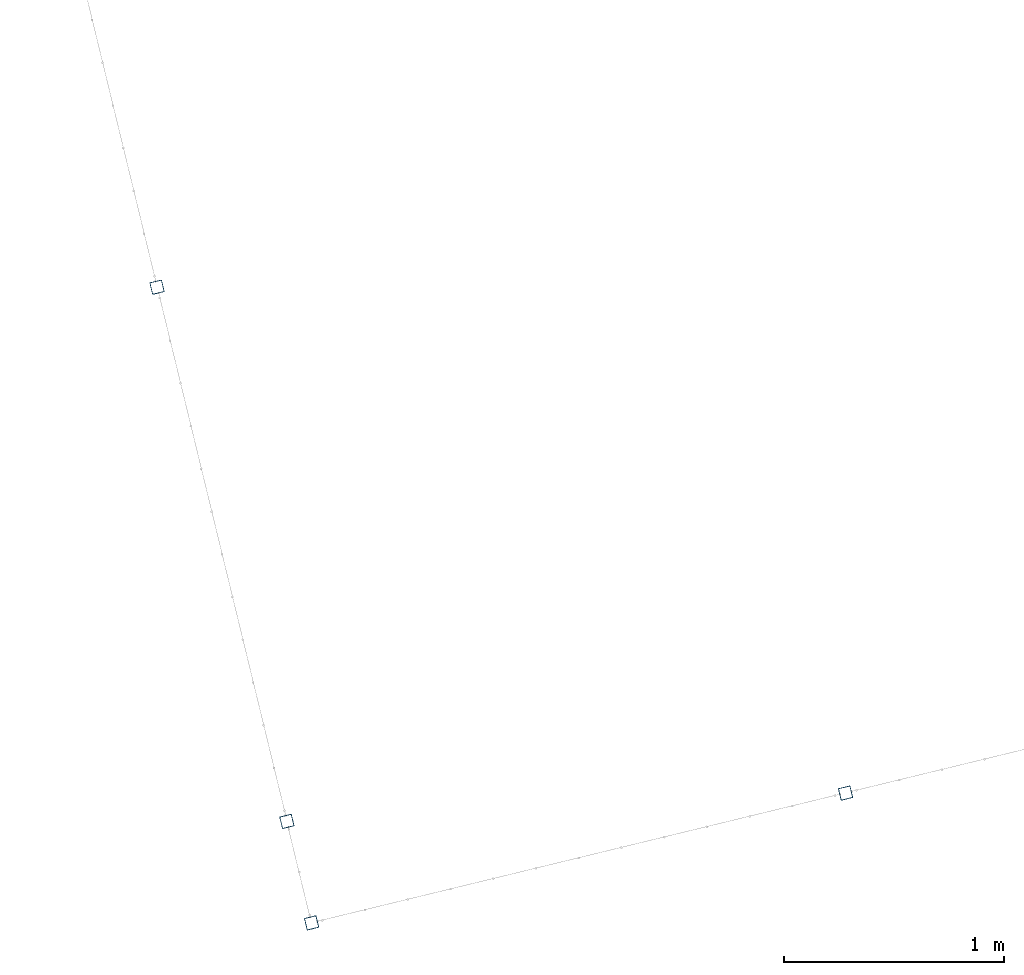
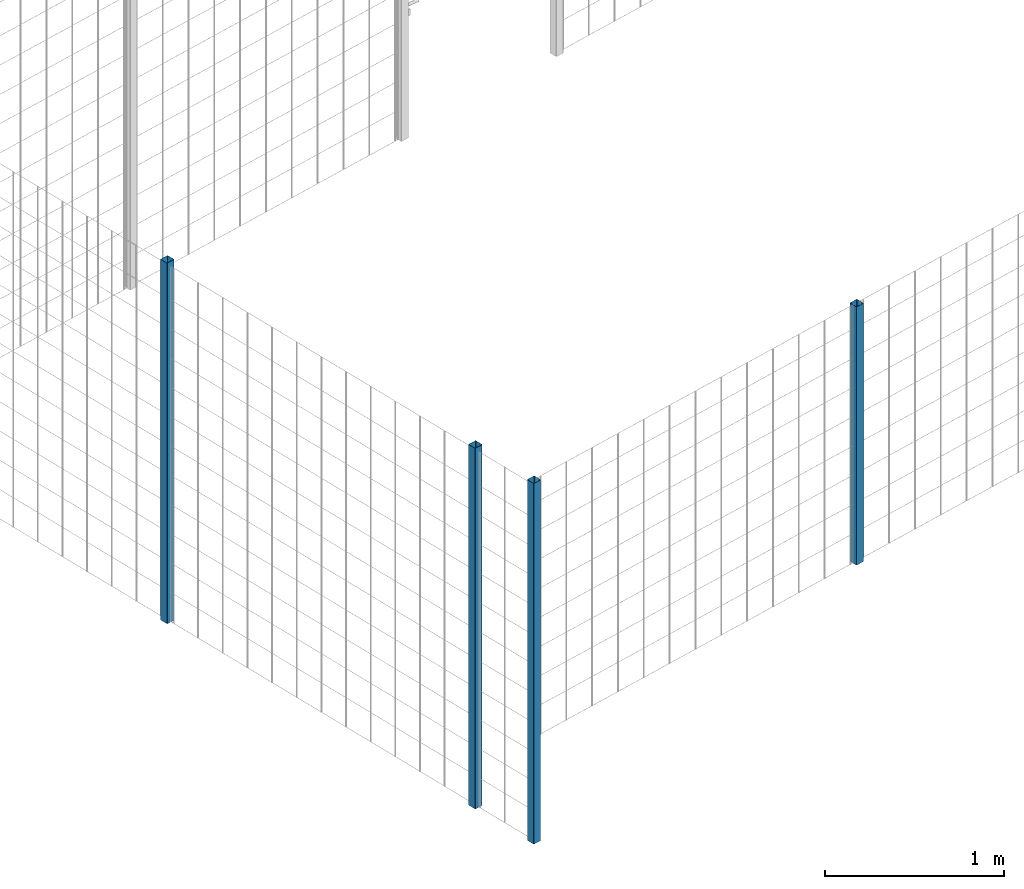
# One storey, part 1 of 10: 4 beams.
"""IFC2X3 building model written with IfcOpenShell, lengths in millimetres."""

from ifc_helpers import new_model, entity, si_unit, converted_unit, derived_unit, direction, frame, frame_2d, origin, place, context, subcontext, project, spatial, polyline, circle_curve, parameter, trimmed, segment, composite_curve, outline, extrude, material, type_object, element, save


model = new_model("IFC2X3")

# Units and contexts
model_context = context("Model", 3, precision=0.01, world=origin(), true_north=direction((6.12303176911189e-17, 1.0)))
body_context = subcontext(model_context, "Body", "Model", "MODEL_VIEW")
ifc_project = project(units=[si_unit("LENGTHUNIT", "METRE", prefix="MILLI"), si_unit("AREAUNIT", "SQUARE_METRE"), si_unit("VOLUMEUNIT", "CUBIC_METRE"), converted_unit("PLANEANGLEUNIT", "DEGREE", entity("IfcRatioMeasure", 0.0174532925199433), si_unit("PLANEANGLEUNIT", "RADIAN"), dimensions=[0, 0, 0, 0, 0, 0, 0]), si_unit("MASSUNIT", "GRAM", prefix="KILO"), derived_unit("MASSDENSITYUNIT", [(si_unit("MASSUNIT", "GRAM", prefix="KILO"), 1), (si_unit("LENGTHUNIT", "METRE"), -3)]), derived_unit("MOMENTOFINERTIAUNIT", [(si_unit("LENGTHUNIT", "METRE"), 4)]), si_unit("TIMEUNIT", "SECOND"), si_unit("FREQUENCYUNIT", "HERTZ"), si_unit("THERMODYNAMICTEMPERATUREUNIT", "DEGREE_CELSIUS"), derived_unit("THERMALTRANSMITTANCEUNIT", [(si_unit("MASSUNIT", "GRAM", prefix="KILO"), 1), (si_unit("THERMODYNAMICTEMPERATUREUNIT", "KELVIN"), -1), (si_unit("TIMEUNIT", "SECOND"), -3)]), derived_unit("VOLUMETRICFLOWRATEUNIT", [(si_unit("LENGTHUNIT", "METRE"), 3), (si_unit("TIMEUNIT", "SECOND"), -1)]), derived_unit("MASSFLOWRATEUNIT", [(si_unit("MASSUNIT", "GRAM", prefix="KILO"), 1), (si_unit("TIMEUNIT", "SECOND"), -1)]), derived_unit("ROTATIONALFREQUENCYUNIT", [(si_unit("TIMEUNIT", "SECOND"), -1)]), si_unit("ELECTRICCURRENTUNIT", "AMPERE"), si_unit("ELECTRICVOLTAGEUNIT", "VOLT"), si_unit("POWERUNIT", "WATT"), si_unit("FORCEUNIT", "NEWTON", prefix="KILO"), si_unit("ILLUMINANCEUNIT", "LUX"), si_unit("LUMINOUSFLUXUNIT", "LUMEN"), si_unit("LUMINOUSINTENSITYUNIT", "CANDELA"), derived_unit("USERDEFINED", [(si_unit("MASSUNIT", "GRAM", prefix="KILO"), -1), (si_unit("LENGTHUNIT", "METRE"), -2), (si_unit("TIMEUNIT", "SECOND"), 3), (si_unit("LUMINOUSFLUXUNIT", "LUMEN"), 1)]), derived_unit("LINEARVELOCITYUNIT", [(si_unit("LENGTHUNIT", "METRE"), 1), (si_unit("TIMEUNIT", "SECOND"), -1)]), si_unit("PRESSUREUNIT", "PASCAL"), derived_unit("USERDEFINED", [(si_unit("LENGTHUNIT", "METRE"), -2), (si_unit("MASSUNIT", "GRAM", prefix="KILO"), 1), (si_unit("TIMEUNIT", "SECOND"), -2)]), derived_unit("LINEARFORCEUNIT", [(si_unit("MASSUNIT", "GRAM", prefix="KILO"), 1), (si_unit("LENGTHUNIT", "METRE"), 1), (si_unit("TIMEUNIT", "SECOND"), -2), (si_unit("LENGTHUNIT", "METRE"), -1)]), derived_unit("PLANARFORCEUNIT", [(si_unit("MASSUNIT", "GRAM", prefix="KILO"), 1), (si_unit("LENGTHUNIT", "METRE"), 1), (si_unit("TIMEUNIT", "SECOND"), -2), (si_unit("LENGTHUNIT", "METRE"), -2)])], contexts=[model_context])

# Site, building, storey
site_placement = place(None, frame((19171.746869958, -72498.5768491146, 0.0), z_axis=(0.0, 0.0, 1.0), x_axis=(0.971695960795463, 0.236234967296933, 0.0)))
site = spatial("IfcSite", under=ifc_project, at=site_placement, CompositionType="ELEMENT")
building_placement = place(site_placement, origin())
building = spatial("IfcBuilding", under=site, at=building_placement, CompositionType="ELEMENT")
storey_placement = place(building_placement, origin())
storey = spatial("IfcBuildingStorey", under=building, at=storey_placement, CompositionType="ELEMENT", Elevation=0.0)

# Beams
ifc_material = material()
beam_type = type_object("IfcBeamType", PredefinedType="NOTDEFINED")
beam_1_placement = place(storey_placement, frame((2669.76839101173, 95.9047277640865, 699.02077554174), z_axis=(1.0, 0.0, 0.0), x_axis=(0.0, 0.0, 1.0)))
element("IfcBeam", 1, at=beam_1_placement, inside=storey, type_object=beam_type, material=ifc_material, context=body_context, shape_type="SweptSolid", body=[
    extrude(outline(composite_curve([segment(trimmed(circle_curve(frame_2d((24.6999999999999, -24.6999999999997), x_axis=(1.0, 0.0)), 2.79999999999974), [parameter(269.999999999999)], [parameter(1.32311074748882e-12)], True, "PARAMETER"), True, "CONTINUOUS"), segment(polyline([(27.4999999999996, -24.6999999999997), (27.4999999999983, 24.7000000000004)]), True, "CONTINUOUS"), segment(trimmed(circle_curve(frame_2d((24.6999999999998, 24.7000000000004), x_axis=(1.0, 0.0)), 2.79999999999845), [parameter(1.32311074748882e-12)], [parameter(90.0000000000001)], True, "PARAMETER"), True, "CONTINUOUS"), segment(polyline([(24.6999999999999, 27.4999999999987), (-24.7000000000002, 27.4999999999986)]), True, "CONTINUOUS"), segment(trimmed(circle_curve(frame_2d((-24.7000000000002, 24.7000000000003), x_axis=(1.0, 0.0)), 2.79999999999845), [parameter(90.0000000000001)], [parameter(180.0)], True, "PARAMETER"), True, "CONTINUOUS"), segment(polyline([(-27.4999999999986, 24.7000000000003), (-27.4999999999986, -24.6999999999999)]), True, "CONTINUOUS"), segment(trimmed(circle_curve(frame_2d((-24.7000000000001, -24.6999999999999), x_axis=(1.0, 0.0)), 2.79999999999845), [parameter(180.0)], [parameter(269.999999999998)], True, "PARAMETER"), True, "CONTINUOUS"), segment(polyline([(-24.7000000000002, -27.4999999999981), (24.6999999999999, -27.4999999999996)]), True, "CONTINUOUS")], self_intersect=False), holes=[composite_curve([segment(polyline([(23.2999999999995, -26.1), (-23.3000000000005, -26.0999999999995)]), True, "CONTINUOUS"), segment(trimmed(circle_curve(frame_2d((-23.3000000000005, -23.3000000000002), x_axis=(1.0, 0.0)), 2.79999999999973), [parameter(180.0)], [parameter(270.0)], True, "PARAMETER"), False, "CONTINUOUS"), segment(polyline([(-26.1000000000002, -23.2999999999996), (-26.1000000000002, 23.3000000000001)]), True, "CONTINUOUS"), segment(trimmed(circle_curve(frame_2d((-23.3000000000005, 23.3000000000001), x_axis=(1.0, 0.0)), 2.79999999999973), [parameter(90.0000000000004)], [parameter(180.0)], True, "PARAMETER"), False, "CONTINUOUS"), segment(polyline([(-23.3000000000005, 26.1), (23.2999999999995, 26.1000000000001)]), True, "CONTINUOUS"), segment(trimmed(circle_curve(frame_2d((23.2999999999995, 23.3000000000002), x_axis=(1.0, 0.0)), 2.79999999999973), [parameter(3.56222124323914e-13)], [parameter(90.0000000000004)], True, "PARAMETER"), False, "CONTINUOUS"), segment(polyline([(26.0999999999992, 23.3000000000002), (26.0999999999999, -23.2999999999995)]), True, "CONTINUOUS"), segment(trimmed(circle_curve(frame_2d((23.2999999999995, -23.3000000000001), x_axis=(1.0, 0.0)), 2.80000000000034), [parameter(270.0)], [parameter(4.57999874130747e-13)], True, "PARAMETER"), False, "CONTINUOUS")], self_intersect=False)]), frame((0.0, -29.0952722359147, 29.0952722359145), z_axis=(1.0, 0.0, 0.0), x_axis=(0.0, -1.0, 0.0)), (0.0, 0.0, 1.0), 1765.97922445826),
])
beam_2_placement = place(storey_placement, frame((170.904727764063, 95.9047277640865, -0.979224458259607), z_axis=(1.0, 0.0, 0.0), x_axis=(0.0, 0.0, 1.0)))
element("IfcBeam", 2, at=beam_2_placement, inside=storey, type_object=beam_type, material=ifc_material, context=body_context, shape_type="SweptSolid", body=[
    extrude(outline(composite_curve([segment(trimmed(circle_curve(frame_2d((24.6999999999998, -24.6999999999999), x_axis=(1.0, 0.0)), 2.79999999999974), [parameter(269.999999999999)], [parameter(1.32311074748882e-12)], True, "PARAMETER"), True, "CONTINUOUS"), segment(polyline([(27.4999999999996, -24.6999999999999), (27.4999999999983, 24.7000000000002)]), True, "CONTINUOUS"), segment(trimmed(circle_curve(frame_2d((24.6999999999998, 24.7000000000002), x_axis=(1.0, 0.0)), 2.79999999999845), [parameter(1.32311074748882e-12)], [parameter(90.0000000000001)], True, "PARAMETER"), True, "CONTINUOUS"), segment(polyline([(24.6999999999998, 27.4999999999987), (-24.7000000000002, 27.4999999999987)]), True, "CONTINUOUS"), segment(trimmed(circle_curve(frame_2d((-24.7000000000002, 24.7000000000002), x_axis=(1.0, 0.0)), 2.79999999999845), [parameter(90.0000000000001)], [parameter(180.0)], True, "PARAMETER"), True, "CONTINUOUS"), segment(polyline([(-27.4999999999986, 24.7000000000002), (-27.4999999999986, -24.6999999999999)]), True, "CONTINUOUS"), segment(trimmed(circle_curve(frame_2d((-24.7000000000002, -24.6999999999999), x_axis=(1.0, 0.0)), 2.79999999999845), [parameter(180.0)], [parameter(269.999999999998)], True, "PARAMETER"), True, "CONTINUOUS"), segment(polyline([(-24.7000000000002, -27.4999999999983), (24.6999999999998, -27.4999999999996)]), True, "CONTINUOUS")], self_intersect=False), holes=[composite_curve([segment(polyline([(23.2999999999995, -26.1000000000001), (-23.3000000000005, -26.0999999999995)]), True, "CONTINUOUS"), segment(trimmed(circle_curve(frame_2d((-23.3000000000005, -23.2999999999998), x_axis=(1.0, 0.0)), 2.79999999999973), [parameter(180.0)], [parameter(270.0)], True, "PARAMETER"), False, "CONTINUOUS"), segment(polyline([(-26.1000000000003, -23.2999999999998), (-26.1000000000002, 23.3000000000002)]), True, "CONTINUOUS"), segment(trimmed(circle_curve(frame_2d((-23.3000000000005, 23.3000000000002), x_axis=(1.0, 0.0)), 2.79999999999973), [parameter(90.0000000000004)], [parameter(180.0)], True, "PARAMETER"), False, "CONTINUOUS"), segment(polyline([(-23.3000000000005, 26.0999999999999), (23.2999999999995, 26.0999999999999)]), True, "CONTINUOUS"), segment(trimmed(circle_curve(frame_2d((23.2999999999995, 23.3000000000002), x_axis=(1.0, 0.0)), 2.79999999999973), [parameter(3.56222124323914e-13)], [parameter(90.0000000000004)], True, "PARAMETER"), False, "CONTINUOUS"), segment(polyline([(26.0999999999992, 23.3000000000002), (26.0999999999998, -23.2999999999998)]), True, "CONTINUOUS"), segment(trimmed(circle_curve(frame_2d((23.2999999999995, -23.2999999999998), x_axis=(1.0, 0.0)), 2.80000000000034), [parameter(270.0)], [parameter(4.57999874130747e-13)], True, "PARAMETER"), False, "CONTINUOUS")], self_intersect=False)]), frame((0.0, -29.0952722359147, 29.0952722359169), z_axis=(1.0, 0.0, 0.0), x_axis=(0.0, -1.0, 0.0)), (0.0, 0.0, 1.0), 2465.97922445826),
])
beam_3_placement = place(storey_placement, frame((170.904727764063, 570.904727764087, -0.979224458259607), z_axis=(1.0, 0.0, 0.0), x_axis=(0.0, 0.0, 1.0)))
element("IfcBeam", 3, at=beam_3_placement, inside=storey, type_object=beam_type, material=ifc_material, context=body_context, shape_type="SweptSolid", body=[
    extrude(outline(composite_curve([segment(trimmed(circle_curve(frame_2d((24.6999999999999, -24.6999999999999), x_axis=(1.0, 0.0)), 2.79999999999974), [parameter(269.999999999999)], [parameter(1.32311074748882e-12)], True, "PARAMETER"), True, "CONTINUOUS"), segment(polyline([(27.4999999999995, -24.6999999999999), (27.4999999999983, 24.7000000000002)]), True, "CONTINUOUS"), segment(trimmed(circle_curve(frame_2d((24.6999999999997, 24.7000000000002), x_axis=(1.0, 0.0)), 2.79999999999845), [parameter(1.32311074748882e-12)], [parameter(90.0000000000001)], True, "PARAMETER"), True, "CONTINUOUS"), segment(polyline([(24.6999999999997, 27.4999999999987), (-24.7000000000002, 27.4999999999987)]), True, "CONTINUOUS"), segment(trimmed(circle_curve(frame_2d((-24.7000000000002, 24.7000000000002), x_axis=(1.0, 0.0)), 2.79999999999845), [parameter(90.0000000000001)], [parameter(180.0)], True, "PARAMETER"), True, "CONTINUOUS"), segment(polyline([(-27.4999999999986, 24.7000000000002), (-27.4999999999986, -24.6999999999999)]), True, "CONTINUOUS"), segment(trimmed(circle_curve(frame_2d((-24.7000000000002, -24.6999999999999), x_axis=(1.0, 0.0)), 2.79999999999845), [parameter(180.0)], [parameter(269.999999999998)], True, "PARAMETER"), True, "CONTINUOUS"), segment(polyline([(-24.7000000000001, -27.4999999999984), (24.6999999999999, -27.4999999999997)]), True, "CONTINUOUS")], self_intersect=False), holes=[composite_curve([segment(polyline([(23.2999999999996, -26.1000000000002), (-23.3000000000005, -26.0999999999996)]), True, "CONTINUOUS"), segment(trimmed(circle_curve(frame_2d((-23.3000000000005, -23.2999999999998), x_axis=(1.0, 0.0)), 2.79999999999973), [parameter(180.0)], [parameter(270.0)], True, "PARAMETER"), False, "CONTINUOUS"), segment(polyline([(-26.1000000000002, -23.2999999999998), (-26.1000000000002, 23.3000000000002)]), True, "CONTINUOUS"), segment(trimmed(circle_curve(frame_2d((-23.3000000000005, 23.3000000000002), x_axis=(1.0, 0.0)), 2.79999999999973), [parameter(90.0000000000004)], [parameter(180.0)], True, "PARAMETER"), False, "CONTINUOUS"), segment(polyline([(-23.3000000000005, 26.0999999999999), (23.2999999999995, 26.0999999999999)]), True, "CONTINUOUS"), segment(trimmed(circle_curve(frame_2d((23.2999999999995, 23.3000000000002), x_axis=(1.0, 0.0)), 2.79999999999973), [parameter(3.56222124323914e-13)], [parameter(90.0000000000004)], True, "PARAMETER"), False, "CONTINUOUS"), segment(polyline([(26.0999999999992, 23.3000000000002), (26.0999999999998, -23.2999999999999)]), True, "CONTINUOUS"), segment(trimmed(circle_curve(frame_2d((23.2999999999996, -23.2999999999998), x_axis=(1.0, 0.0)), 2.80000000000034), [parameter(270.0)], [parameter(4.57999874130747e-13)], True, "PARAMETER"), False, "CONTINUOUS")], self_intersect=False)]), frame((0.0, -29.0952722359146, 29.0952722359169), z_axis=(1.0, 0.0, 0.0), x_axis=(0.0, -1.0, 0.0)), (0.0, 0.0, 1.0), 2465.97922445826),
])
beam_4_placement = place(storey_placement, frame((170.904727764063, 3070.90472776409, -0.979224458259607), z_axis=(1.0, 0.0, 0.0), x_axis=(0.0, 0.0, 1.0)))
element("IfcBeam", 4, at=beam_4_placement, inside=storey, type_object=beam_type, material=ifc_material, context=body_context, shape_type="SweptSolid", body=[
    extrude(outline(composite_curve([segment(trimmed(circle_curve(frame_2d((24.6999999999999, -24.6999999999999), x_axis=(1.0, 0.0)), 2.79999999999974), [parameter(269.999999999999)], [parameter(1.32311074748882e-12)], True, "PARAMETER"), True, "CONTINUOUS"), segment(polyline([(27.4999999999998, -24.6999999999999), (27.4999999999986, 24.7000000000002)]), True, "CONTINUOUS"), segment(trimmed(circle_curve(frame_2d((24.6999999999997, 24.7000000000002), x_axis=(1.0, 0.0)), 2.79999999999845), [parameter(1.32311074748882e-12)], [parameter(90.0000000000001)], True, "PARAMETER"), True, "CONTINUOUS"), segment(polyline([(24.6999999999997, 27.4999999999987), (-24.6999999999999, 27.4999999999987)]), True, "CONTINUOUS"), segment(trimmed(circle_curve(frame_2d((-24.7000000000004, 24.7000000000002), x_axis=(1.0, 0.0)), 2.79999999999845), [parameter(90.0000000000001)], [parameter(180.0)], True, "PARAMETER"), True, "CONTINUOUS"), segment(polyline([(-27.4999999999987, 24.7000000000002), (-27.4999999999986, -24.6999999999999)]), True, "CONTINUOUS"), segment(trimmed(circle_curve(frame_2d((-24.7000000000003, -24.6999999999999), x_axis=(1.0, 0.0)), 2.79999999999845), [parameter(180.0)], [parameter(269.999999999998)], True, "PARAMETER"), True, "CONTINUOUS"), segment(polyline([(-24.7000000000003, -27.4999999999984), (24.6999999999999, -27.4999999999997)]), True, "CONTINUOUS")], self_intersect=False), holes=[composite_curve([segment(polyline([(23.2999999999996, -26.1000000000002), (-23.3000000000006, -26.0999999999996)]), True, "CONTINUOUS"), segment(trimmed(circle_curve(frame_2d((-23.3000000000006, -23.2999999999998), x_axis=(1.0, 0.0)), 2.79999999999973), [parameter(180.0)], [parameter(270.0)], True, "PARAMETER"), False, "CONTINUOUS"), segment(polyline([(-26.1, -23.2999999999998), (-26.1000000000001, 23.3000000000002)]), True, "CONTINUOUS"), segment(trimmed(circle_curve(frame_2d((-23.3000000000007, 23.3000000000002), x_axis=(1.0, 0.0)), 2.79999999999973), [parameter(90.0000000000004)], [parameter(180.0)], True, "PARAMETER"), False, "CONTINUOUS"), segment(polyline([(-23.3000000000002, 26.0999999999999), (23.2999999999995, 26.0999999999999)]), True, "CONTINUOUS"), segment(trimmed(circle_curve(frame_2d((23.2999999999995, 23.3000000000002), x_axis=(1.0, 0.0)), 2.79999999999973), [parameter(3.56222124323914e-13)], [parameter(90.0000000000004)], True, "PARAMETER"), False, "CONTINUOUS"), segment(polyline([(26.0999999999994, 23.3000000000002), (26.1000000000001, -23.2999999999999)]), True, "CONTINUOUS"), segment(trimmed(circle_curve(frame_2d((23.2999999999996, -23.2999999999998), x_axis=(1.0, 0.0)), 2.80000000000034), [parameter(270.0)], [parameter(4.57999874130747e-13)], True, "PARAMETER"), False, "CONTINUOUS")], self_intersect=False)]), frame((0.0, -29.0952722359145, 29.0952722359169), z_axis=(1.0, 0.0, 0.0), x_axis=(0.0, -1.0, 0.0)), (0.0, 0.0, 1.0), 2465.97922445826),
])

save(model, "model.ifc")
